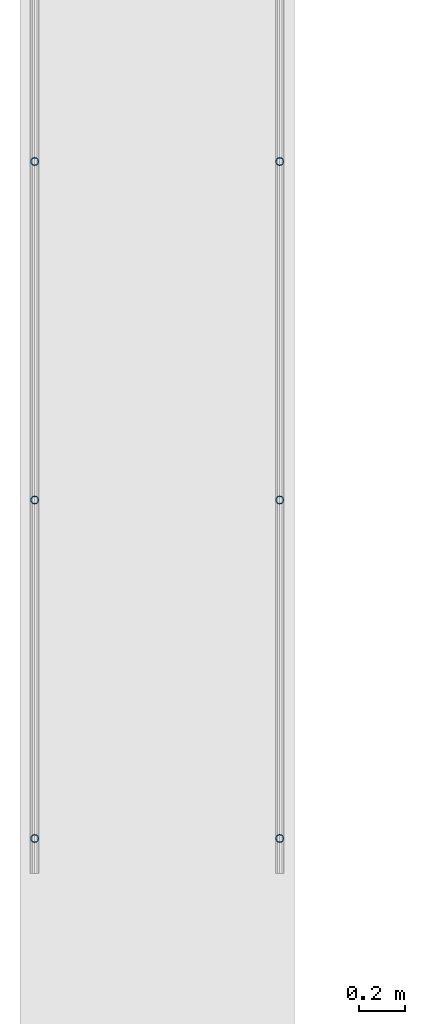
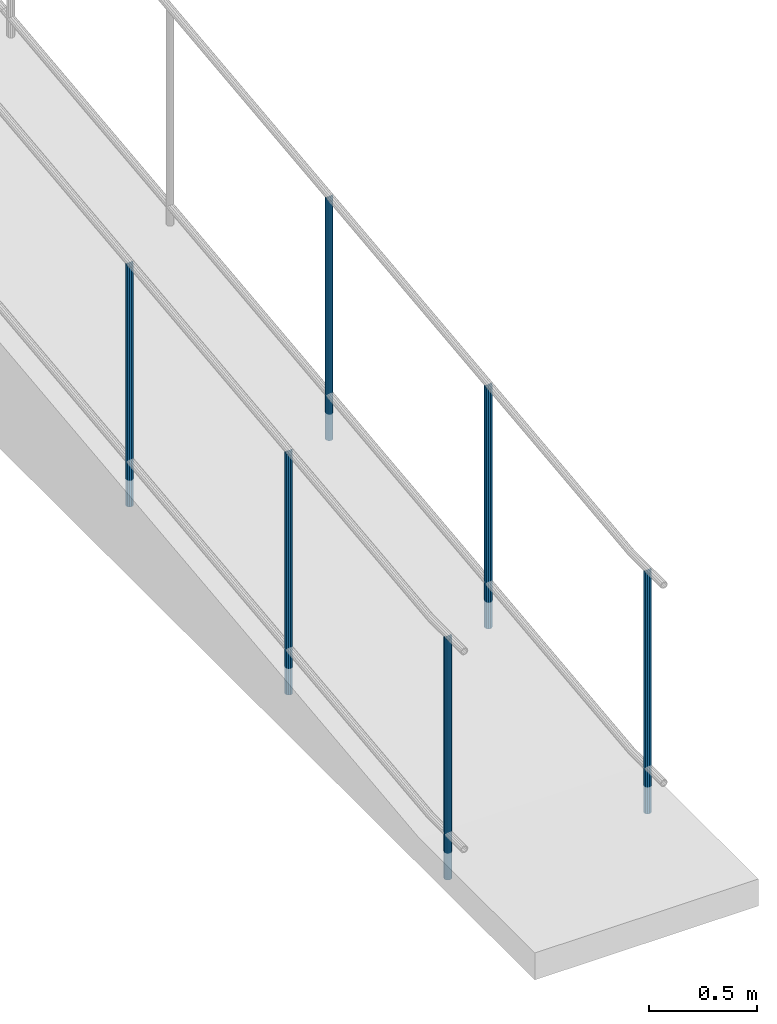
# One storey, part 871 of 1763: 6 columns, 2 elements without a shape of their own.
"""IFC2X3 building model written with IfcOpenShell, lengths in millimetres."""

from ifc_helpers import new_model, si_unit, frame, origin_with_axes, place, context, subcontext, project, spatial, faceted_brep, material, type_object, element, aggregate, save


model = new_model("IFC2X3")

# Units and contexts
model_context = context("Model", 3, precision=1e-05, world=origin_with_axes())
body_context = subcontext(model_context, "Body", "Model", "MODEL_VIEW")
ifc_project = project(units=[si_unit("LENGTHUNIT", "METRE", prefix="MILLI"), si_unit("AREAUNIT", "SQUARE_METRE"), si_unit("VOLUMEUNIT", "CUBIC_METRE"), si_unit("MASSUNIT", "GRAM", prefix="KILO"), si_unit("TIMEUNIT", "SECOND"), si_unit("PLANEANGLEUNIT", "RADIAN"), si_unit("SOLIDANGLEUNIT", "STERADIAN"), si_unit("THERMODYNAMICTEMPERATUREUNIT", "DEGREE_CELSIUS"), si_unit("LUMINOUSINTENSITYUNIT", "LUMEN")], contexts=[model_context])

# Site, building, storey
site_placement = place(None, origin_with_axes())
site = spatial("IfcSite", under=ifc_project, at=site_placement, CompositionType="ELEMENT")
building_placement = place(site_placement, origin_with_axes())
building = spatial("IfcBuilding", under=site, at=building_placement, Name="Undefined", CompositionType="ELEMENT")
storey_placement = place(building_placement, origin_with_axes())
storey = spatial("IfcBuildingStorey", under=building, at=storey_placement, Name="Undefined", CompositionType="ELEMENT", Elevation=0.0)

# Assembly, columns
assembly_1_placement = place(storey_placement, origin_with_axes())
assembly_1 = element("IfcElementAssembly", 1, at=assembly_1_placement, inside=storey, Name="GUARDRAIL", AssemblyPlace="NOTDEFINED", PredefinedType="RIGID_FRAME")
ifc_material = material(Name="STEEL/A513")
column_type = type_object("IfcColumnType", PredefinedType="NOTDEFINED")
column_1_placement = place(assembly_1_placement, frame((-97200.6527017878, -14255.9625831118, 3409.94906001946), z_axis=(0.0, -0.999999999989044, 4.68099999989136e-06), x_axis=(0.0, 4.68100000009712e-06, 0.999999999989044)))
column_1 = element("IfcColumn", 2, at=column_1_placement, type_object=column_type, material=ifc_material, Name="POST TUBE", context=body_context, shape_type="Brep", body=[
    faceted_brep([(1355.10215161049, -9.52499999999418, 16.4977839420062), (1355.10216136252, -9.52499999999418, 9.99208795648156), (1354.46410377855, -7.14375000000291, 12.3733379564819), (1352.54993886579, 0.0, 14.2874999999131), (1352.5499317268, 0.0, 19.0499999999138), (1354.46410377855, 7.14375000000291, 12.3733379564819), (1355.10216136252, 9.52499999999418, 9.99208795648156), (1355.10215161049, 9.52499999999418, 16.4977839420062), (1371.59999999763, 19.0500000000029, -8.9130480773747e-11), (1362.07494600479, 16.4977839420899, 9.52499999991051), (1362.07497456074, 16.4977839420899, -9.52500000008877), (1357.95050358876, 12.3733379565674, 7.14374999991196), (1359.86467634067, 14.2875000000058, -8.9130480773747e-11), (1357.95052500572, 12.3733379565674, -7.1437500000884), (1355.1021913188, 9.52499999999418, -9.992087956658), (1355.10220107084, 9.52499999999418, -16.4977839421827), (1354.46414087382, 7.14375000000291, -12.3733379566584), (1352.54998169972, 0.0, -14.2875000000895), (1352.5499888387, 0.0, -19.0500000000884), (1355.1021913188, -9.52499999999418, -9.992087956658), (1355.10220107084, -9.52499999999418, -16.4977839421827), (1354.46414087382, -7.14375000000291, -12.3733379566584), (1371.59996028277, -19.0500000000029, -1.4915713109076e-10), (1362.07497456074, -16.4977839420899, -9.52500000008877), (1362.07494600479, -16.4977839420899, 9.52499999991051), (1357.95052500571, -12.3733379565674, -7.1437500000884), (1359.86467634067, -14.2875000000058, -8.9130480773747e-11), (1357.95050358875, -12.3733379565674, 7.14374999991196), (0.0, -16.4977839420899, -9.52500000000146), (0.0, -9.52499999999418, -16.4977839420935), (1.45519152283669e-11, 1.81898940354586e-12, -19.0499999999993), (0.0, 9.52499999999418, -16.4977839420935), (0.0, 16.4977839420899, -9.52500000000146), (0.0, 19.0500000000029, 0.0), (0.0, 16.4977839420899, 9.52500000000146), (0.0, 9.52499999999418, 16.4977839420935), (1.45519152283669e-11, 1.81898940354586e-12, 19.0499999999993), (0.0, -9.52499999999418, 16.4977839420935), (0.0, -16.4977839420899, 9.52500000000146), (0.0, -19.0500000000029, 0.0), (0.0, -12.3733379565674, -7.14374999999927), (0.0, -7.14375000000291, -12.373337956571), (0.0, 0.0, -14.2874999999985), (0.0, 7.14375000000291, -12.373337956571), (0.0, 12.3733379565674, -7.14374999999927), (0.0, 14.2875000000058, 0.0), (0.0, 12.3733379565674, 7.14374999999927), (0.0, 7.14375000000291, 12.373337956571), (0.0, 0.0, 14.2874999999985), (0.0, -7.14375000000291, 12.373337956571), (0.0, -12.3733379565674, 7.14374999999927), (0.0, -14.2875000000058, 0.0)], [[[0, 1, 2, 3, 4]], [[4, 3, 5, 6, 7]], [[8, 9, 10]], [[7, 6, 11, 12, 13, 14, 15, 10, 9]], [[16, 17, 18, 15, 14]], [[19, 20, 18, 17, 21]], [[22, 23, 24]], [[24, 23, 20, 19, 25, 26, 27, 1, 0]], [[28, 29, 20, 23]], [[29, 30, 18, 20]], [[30, 31, 15, 18]], [[31, 32, 10, 15]], [[32, 33, 8, 10]], [[33, 34, 9, 8]], [[34, 35, 7, 9]], [[35, 36, 4, 7]], [[36, 37, 0, 4]], [[37, 38, 24, 0]], [[38, 39, 22, 24]], [[39, 28, 23, 22]], [[38, 37, 36, 35, 34, 33, 32, 31, 30, 29, 28, 39], [40, 41, 42, 43, 44, 45, 46, 47, 48, 49, 50, 51]], [[40, 51, 26, 25]], [[21, 41, 40, 25, 19]], [[42, 41, 21, 17]], [[43, 42, 17, 16]], [[44, 43, 16, 14, 13]], [[45, 44, 13, 12]], [[46, 45, 12, 11]], [[5, 47, 46, 11, 6]], [[48, 47, 5, 3]], [[49, 48, 3, 2]], [[50, 49, 2, 1, 27]], [[51, 50, 27, 26]]]),
])
column_2_placement = place(assembly_1_placement, frame((-97200.6527017878, -11309.562666814, 3730.72595269953), z_axis=(0.0, -0.999999999989044, 4.68099999989136e-06), x_axis=(0.0, 4.68100000009712e-06, 0.999999999989044)))
column_2 = element("IfcColumn", 3, at=column_2_placement, type_object=column_type, material=ifc_material, Name="POST TUBE", context=body_context, shape_type="Brep", body=[
    faceted_brep([(1371.60074802696, 19.0500000000029, -4.95674612466246e-10), (1360.91954353543, 16.4977839420899, 9.52499999992688), (1363.1068023618, 16.4977839420899, -9.52500000007285), (1352.93166657158, -7.14375000000291, 12.3733379564974), (1350.78515091293, 0.0, 14.2874999999276), (1350.23833620634, 0.0, 19.0499999999279), (1353.10035708436, -9.52499999999418, 16.4977839420208), (1353.84731986472, -9.52499999997963, 9.99208795651202), (1353.84731986473, 9.52500000000873, 9.99208795648292), (1353.10035708436, 9.52499999999418, 16.4977839420208), (1352.93166657157, 7.14375000000291, 12.3733379564974), (1357.04140787087, 12.3733379565674, 7.14374999992697), (1359.7883677507, 14.2875000000058, -7.27595761418343e-11), (1358.68185199063, 12.3733379565674, -7.14375000007294), (1356.14183772056, 9.52500000000873, -9.99208795662844), (1356.88880050093, 9.52499999999418, -16.4977839421663), (1355.77299913398, 7.14375000000291, -12.3733379566434), (1354.06603915248, 0.0, -14.2875000000727), (1354.61285385908, 0.0, -19.0500000000725), (1355.77299913399, -7.14375000000291, -12.3733379566434), (1356.14183772056, -9.52499999997963, -9.992087956658), (1356.88880050093, -9.52499999999418, -16.4977839421663), (1371.60075086449, -19.0499999999884, 1.21417542686686e-10), (1363.1068023618, -16.4977839420899, -9.52500000007285), (1360.91954353543, -16.4977839420899, 9.52499999992688), (1358.68185199066, -12.3733379565674, -7.14375000007294), (1359.78836775073, -14.2875000000058, -7.27595761418343e-11), (1357.0414078709, -12.3733379565674, 7.14374999992697), (0.0, -16.4977839420899, -9.52500000000146), (0.0, -9.52499999999418, -16.4977839420935), (1.45519152283669e-11, 1.81898940354586e-12, -19.0499999999993), (0.0, 9.52499999999418, -16.4977839420935), (0.0, 16.4977839420899, -9.52500000000146), (0.0, 19.0500000000029, 0.0), (0.0, 16.4977839420899, 9.52500000000146), (0.0, 9.52499999999418, 16.4977839420935), (1.45519152283669e-11, 1.81898940354586e-12, 19.0499999999993), (0.0, -9.52499999999418, 16.4977839420935), (0.0, -16.4977839420899, 9.52500000000146), (0.0, -19.0500000000029, 0.0), (0.0, -12.3733379565674, -7.14374999999927), (0.0, -7.14375000000291, -12.373337956571), (0.0, 0.0, -14.2874999999985), (0.0, 7.14375000000291, -12.373337956571), (0.0, 12.3733379565674, -7.14374999999927), (0.0, 14.2875000000058, 0.0), (0.0, 12.3733379565674, 7.14374999999927), (0.0, 7.14375000000291, 12.373337956571), (0.0, 0.0, 14.2874999999985), (0.0, -7.14375000000291, 12.373337956571), (0.0, -12.3733379565674, 7.14374999999927), (0.0, -14.2875000000058, 0.0)], [[[0, 1, 2]], [[3, 4, 5, 6, 7]], [[8, 9, 5, 4, 10]], [[2, 1, 9, 8, 11, 12, 13, 14, 15]], [[15, 14, 16, 17, 18]], [[18, 17, 19, 20, 21]], [[22, 23, 24]], [[21, 20, 25, 26, 27, 7, 6, 24, 23]], [[28, 29, 21, 23]], [[29, 30, 18, 21]], [[30, 31, 15, 18]], [[31, 32, 2, 15]], [[32, 33, 0, 2]], [[33, 34, 1, 0]], [[34, 35, 9, 1]], [[35, 36, 5, 9]], [[36, 37, 6, 5]], [[37, 38, 24, 6]], [[38, 39, 22, 24]], [[39, 28, 23, 22]], [[38, 37, 36, 35, 34, 33, 32, 31, 30, 29, 28, 39], [40, 41, 42, 43, 44, 45, 46, 47, 48, 49, 50, 51]], [[40, 51, 26, 25]], [[19, 41, 40, 25, 20]], [[42, 41, 19, 17]], [[43, 42, 17, 16]], [[44, 43, 16, 14, 13]], [[45, 44, 13, 12]], [[46, 45, 12, 11]], [[10, 47, 46, 11, 8]], [[48, 47, 10, 4]], [[49, 48, 4, 3]], [[50, 49, 3, 7, 27]], [[51, 50, 27, 26]]]),
])
column_3_placement = place(assembly_1_placement, frame((-97200.6527017878, -12782.7626686429, 3561.58505339819), z_axis=(0.0, -0.999999999989044, 4.68099999989136e-06), x_axis=(0.0, 4.68100000009712e-06, 0.999999999989044)))
column_3 = element("IfcColumn", 4, at=column_3_placement, type_object=column_type, material=ifc_material, Name="POST TUBE", context=body_context, shape_type="Brep", body=[
    faceted_brep([(1371.60074802696, 19.0500000000029, -4.95674612466246e-10), (1360.91954353543, 16.4977839420899, 9.52499999992688), (1363.1068023618, 16.4977839420899, -9.52500000007285), (1352.93166657158, -7.14375000000291, 12.3733379564974), (1350.78515091293, 0.0, 14.2874999999276), (1350.23833620634, 0.0, 19.0499999999279), (1353.10035708436, -9.52499999999418, 16.4977839420208), (1353.84731986472, -9.52499999997963, 9.99208795651202), (1353.84731986473, 9.52500000000873, 9.99208795648292), (1353.10035708436, 9.52499999999418, 16.4977839420208), (1352.93166657157, 7.14375000000291, 12.3733379564974), (1357.04140787087, 12.3733379565674, 7.14374999992697), (1359.7883677507, 14.2875000000058, -7.27595761418343e-11), (1358.68185199063, 12.3733379565674, -7.14375000007294), (1356.14183772056, 9.52500000000873, -9.99208795662844), (1356.88880050093, 9.52499999999418, -16.4977839421663), (1355.77299913398, 7.14375000000291, -12.3733379566434), (1354.06603915248, 0.0, -14.2875000000727), (1354.61285385908, 0.0, -19.0500000000725), (1355.77299913399, -7.14375000000291, -12.3733379566434), (1356.14183772056, -9.52499999997963, -9.992087956658), (1356.88880050093, -9.52499999999418, -16.4977839421663), (1371.60075086449, -19.0499999999884, 1.21417542686686e-10), (1363.1068023618, -16.4977839420899, -9.52500000007285), (1360.91954353543, -16.4977839420899, 9.52499999992688), (1358.68185199066, -12.3733379565674, -7.14375000007294), (1359.78836775073, -14.2875000000058, -7.27595761418343e-11), (1357.0414078709, -12.3733379565674, 7.14374999992697), (0.0, -16.4977839420899, -9.52500000000146), (0.0, -9.52499999999418, -16.4977839420935), (1.45519152283669e-11, 1.81898940354586e-12, -19.0499999999993), (0.0, 9.52499999999418, -16.4977839420935), (0.0, 16.4977839420899, -9.52500000000146), (0.0, 19.0500000000029, 0.0), (0.0, 16.4977839420899, 9.52500000000146), (0.0, 9.52499999999418, 16.4977839420935), (1.45519152283669e-11, 1.81898940354586e-12, 19.0499999999993), (0.0, -9.52499999999418, 16.4977839420935), (0.0, -16.4977839420899, 9.52500000000146), (0.0, -19.0500000000029, 0.0), (0.0, -12.3733379565674, -7.14374999999927), (0.0, -7.14375000000291, -12.373337956571), (0.0, 0.0, -14.2874999999985), (0.0, 7.14375000000291, -12.373337956571), (0.0, 12.3733379565674, -7.14374999999927), (0.0, 14.2875000000058, 0.0), (0.0, 12.3733379565674, 7.14374999999927), (0.0, 7.14375000000291, 12.373337956571), (0.0, 0.0, 14.2874999999985), (0.0, -7.14375000000291, 12.373337956571), (0.0, -12.3733379565674, 7.14374999999927), (0.0, -14.2875000000058, 0.0)], [[[0, 1, 2]], [[3, 4, 5, 6, 7]], [[8, 9, 5, 4, 10]], [[2, 1, 9, 8, 11, 12, 13, 14, 15]], [[15, 14, 16, 17, 18]], [[18, 17, 19, 20, 21]], [[22, 23, 24]], [[21, 20, 25, 26, 27, 7, 6, 24, 23]], [[28, 29, 21, 23]], [[29, 30, 18, 21]], [[30, 31, 15, 18]], [[31, 32, 2, 15]], [[32, 33, 0, 2]], [[33, 34, 1, 0]], [[34, 35, 9, 1]], [[35, 36, 5, 9]], [[36, 37, 6, 5]], [[37, 38, 24, 6]], [[38, 39, 22, 24]], [[39, 28, 23, 22]], [[38, 37, 36, 35, 34, 33, 32, 31, 30, 29, 28, 39], [40, 41, 42, 43, 44, 45, 46, 47, 48, 49, 50, 51]], [[40, 51, 26, 25]], [[19, 41, 40, 25, 20]], [[42, 41, 19, 17]], [[43, 42, 17, 16]], [[44, 43, 16, 14, 13]], [[45, 44, 13, 12]], [[46, 45, 12, 11]], [[10, 47, 46, 11, 8]], [[48, 47, 10, 4]], [[49, 48, 4, 3]], [[50, 49, 3, 7, 27]], [[51, 50, 27, 26]]]),
])
aggregate(assembly_1, [column_1, column_2, column_3])

assembly_2_placement = place(storey_placement, origin_with_axes())
assembly_2 = element("IfcElementAssembly", 5, at=assembly_2_placement, inside=storey, Name="GUARDRAIL", AssemblyPlace="NOTDEFINED", PredefinedType="RIGID_FRAME")
column_4_placement = place(assembly_2_placement, frame((-96133.8527017878, -14255.9625831118, 3409.94906001946), z_axis=(0.0, -0.999999999989044, 4.68099999989136e-06), x_axis=(0.0, 4.68100000009712e-06, 0.999999999989044)))
column_4 = element("IfcColumn", 6, at=column_4_placement, type_object=column_type, material=ifc_material, Name="POST TUBE", context=body_context, shape_type="Brep", body=[
    faceted_brep([(1355.10215161049, -9.52499999999418, 16.4977839420062), (1355.10216136252, -9.52499999999418, 9.99208795648156), (1354.46410377855, -7.14375000000291, 12.3733379564819), (1352.54993886579, 0.0, 14.2874999999131), (1352.5499317268, 0.0, 19.0499999999138), (1354.46410377855, 7.14375000000291, 12.3733379564819), (1355.10216136252, 9.52499999999418, 9.99208795648156), (1355.10215161049, 9.52499999999418, 16.4977839420062), (1371.59999999763, 19.0500000000029, -8.9130480773747e-11), (1362.07494600479, 16.4977839420899, 9.52499999991051), (1362.07497456074, 16.4977839420899, -9.52500000008877), (1357.95050358876, 12.3733379565674, 7.14374999991196), (1359.86467634067, 14.2875000000058, -8.9130480773747e-11), (1357.95052500572, 12.3733379565674, -7.1437500000884), (1355.1021913188, 9.52499999999418, -9.992087956658), (1355.10220107084, 9.52499999999418, -16.4977839421827), (1354.46414087382, 7.14375000000291, -12.3733379566584), (1352.54998169972, 0.0, -14.2875000000895), (1352.5499888387, 0.0, -19.0500000000884), (1355.1021913188, -9.52499999999418, -9.992087956658), (1355.10220107084, -9.52499999999418, -16.4977839421827), (1354.46414087382, -7.14375000000291, -12.3733379566584), (1371.59996028277, -19.0500000000029, -1.4915713109076e-10), (1362.07497456074, -16.4977839420899, -9.52500000008877), (1362.07494600479, -16.4977839420899, 9.52499999991051), (1357.95052500571, -12.3733379565674, -7.1437500000884), (1359.86467634067, -14.2875000000058, -8.9130480773747e-11), (1357.95050358875, -12.3733379565674, 7.14374999991196), (0.0, -16.4977839420899, -9.52500000000146), (0.0, -9.52499999999418, -16.4977839420935), (1.45519152283669e-11, 1.81898940354586e-12, -19.0499999999993), (0.0, 9.52499999999418, -16.4977839420935), (0.0, 16.4977839420899, -9.52500000000146), (0.0, 19.0500000000029, 0.0), (0.0, 16.4977839420899, 9.52500000000146), (0.0, 9.52499999999418, 16.4977839420935), (1.45519152283669e-11, 1.81898940354586e-12, 19.0499999999993), (0.0, -9.52499999999418, 16.4977839420935), (0.0, -16.4977839420899, 9.52500000000146), (0.0, -19.0500000000029, 0.0), (0.0, -12.3733379565674, -7.14374999999927), (0.0, -7.14375000000291, -12.373337956571), (0.0, 0.0, -14.2874999999985), (0.0, 7.14375000000291, -12.373337956571), (0.0, 12.3733379565674, -7.14374999999927), (0.0, 14.2875000000058, 0.0), (0.0, 12.3733379565674, 7.14374999999927), (0.0, 7.14375000000291, 12.373337956571), (0.0, 0.0, 14.2874999999985), (0.0, -7.14375000000291, 12.373337956571), (0.0, -12.3733379565674, 7.14374999999927), (0.0, -14.2875000000058, 0.0)], [[[0, 1, 2, 3, 4]], [[4, 3, 5, 6, 7]], [[8, 9, 10]], [[7, 6, 11, 12, 13, 14, 15, 10, 9]], [[16, 17, 18, 15, 14]], [[19, 20, 18, 17, 21]], [[22, 23, 24]], [[24, 23, 20, 19, 25, 26, 27, 1, 0]], [[28, 29, 20, 23]], [[29, 30, 18, 20]], [[30, 31, 15, 18]], [[31, 32, 10, 15]], [[32, 33, 8, 10]], [[33, 34, 9, 8]], [[34, 35, 7, 9]], [[35, 36, 4, 7]], [[36, 37, 0, 4]], [[37, 38, 24, 0]], [[38, 39, 22, 24]], [[39, 28, 23, 22]], [[38, 37, 36, 35, 34, 33, 32, 31, 30, 29, 28, 39], [40, 41, 42, 43, 44, 45, 46, 47, 48, 49, 50, 51]], [[40, 51, 26, 25]], [[21, 41, 40, 25, 19]], [[42, 41, 21, 17]], [[43, 42, 17, 16]], [[44, 43, 16, 14, 13]], [[45, 44, 13, 12]], [[46, 45, 12, 11]], [[5, 47, 46, 11, 6]], [[48, 47, 5, 3]], [[49, 48, 3, 2]], [[50, 49, 2, 1, 27]], [[51, 50, 27, 26]]]),
])
column_5_placement = place(assembly_2_placement, frame((-96133.8527017878, -11309.562666814, 3730.72595269953), z_axis=(0.0, -0.999999999989044, 4.68099999989136e-06), x_axis=(0.0, 4.68100000009712e-06, 0.999999999989044)))
column_5 = element("IfcColumn", 7, at=column_5_placement, type_object=column_type, material=ifc_material, Name="POST TUBE", context=body_context, shape_type="Brep", body=[
    faceted_brep([(1371.60074802696, 19.0500000000029, -4.95674612466246e-10), (1360.91954353543, 16.4977839420899, 9.52499999992688), (1363.1068023618, 16.4977839420899, -9.52500000007285), (1352.93166657158, -7.14375000000291, 12.3733379564974), (1350.78515091293, 0.0, 14.2874999999276), (1350.23833620634, 0.0, 19.0499999999279), (1353.10035708436, -9.52499999999418, 16.4977839420208), (1353.84731986472, -9.52499999997963, 9.99208795651202), (1353.84731986473, 9.52500000000873, 9.99208795648292), (1353.10035708436, 9.52499999999418, 16.4977839420208), (1352.93166657157, 7.14375000000291, 12.3733379564974), (1357.04140787087, 12.3733379565674, 7.14374999992697), (1359.7883677507, 14.2875000000058, -7.27595761418343e-11), (1358.68185199063, 12.3733379565674, -7.14375000007294), (1356.14183772056, 9.52500000000873, -9.99208795662844), (1356.88880050093, 9.52499999999418, -16.4977839421663), (1355.77299913398, 7.14375000000291, -12.3733379566434), (1354.06603915248, 0.0, -14.2875000000727), (1354.61285385908, 0.0, -19.0500000000725), (1355.77299913399, -7.14375000000291, -12.3733379566434), (1356.14183772056, -9.52499999997963, -9.992087956658), (1356.88880050093, -9.52499999999418, -16.4977839421663), (1371.60075086449, -19.0499999999884, 1.21417542686686e-10), (1363.1068023618, -16.4977839420899, -9.52500000007285), (1360.91954353543, -16.4977839420899, 9.52499999992688), (1358.68185199066, -12.3733379565674, -7.14375000007294), (1359.78836775073, -14.2875000000058, -7.27595761418343e-11), (1357.0414078709, -12.3733379565674, 7.14374999992697), (0.0, -16.4977839420899, -9.52500000000146), (0.0, -9.52499999999418, -16.4977839420935), (1.45519152283669e-11, 1.81898940354586e-12, -19.0499999999993), (0.0, 9.52499999999418, -16.4977839420935), (0.0, 16.4977839420899, -9.52500000000146), (0.0, 19.0500000000029, 0.0), (0.0, 16.4977839420899, 9.52500000000146), (0.0, 9.52499999999418, 16.4977839420935), (1.45519152283669e-11, 1.81898940354586e-12, 19.0499999999993), (0.0, -9.52499999999418, 16.4977839420935), (0.0, -16.4977839420899, 9.52500000000146), (0.0, -19.0500000000029, 0.0), (0.0, -12.3733379565674, -7.14374999999927), (0.0, -7.14375000000291, -12.373337956571), (0.0, 0.0, -14.2874999999985), (0.0, 7.14375000000291, -12.373337956571), (0.0, 12.3733379565674, -7.14374999999927), (0.0, 14.2875000000058, 0.0), (0.0, 12.3733379565674, 7.14374999999927), (0.0, 7.14375000000291, 12.373337956571), (0.0, 0.0, 14.2874999999985), (0.0, -7.14375000000291, 12.373337956571), (0.0, -12.3733379565674, 7.14374999999927), (0.0, -14.2875000000058, 0.0)], [[[0, 1, 2]], [[3, 4, 5, 6, 7]], [[8, 9, 5, 4, 10]], [[2, 1, 9, 8, 11, 12, 13, 14, 15]], [[15, 14, 16, 17, 18]], [[18, 17, 19, 20, 21]], [[22, 23, 24]], [[21, 20, 25, 26, 27, 7, 6, 24, 23]], [[28, 29, 21, 23]], [[29, 30, 18, 21]], [[30, 31, 15, 18]], [[31, 32, 2, 15]], [[32, 33, 0, 2]], [[33, 34, 1, 0]], [[34, 35, 9, 1]], [[35, 36, 5, 9]], [[36, 37, 6, 5]], [[37, 38, 24, 6]], [[38, 39, 22, 24]], [[39, 28, 23, 22]], [[38, 37, 36, 35, 34, 33, 32, 31, 30, 29, 28, 39], [40, 41, 42, 43, 44, 45, 46, 47, 48, 49, 50, 51]], [[40, 51, 26, 25]], [[19, 41, 40, 25, 20]], [[42, 41, 19, 17]], [[43, 42, 17, 16]], [[44, 43, 16, 14, 13]], [[45, 44, 13, 12]], [[46, 45, 12, 11]], [[10, 47, 46, 11, 8]], [[48, 47, 10, 4]], [[49, 48, 4, 3]], [[50, 49, 3, 7, 27]], [[51, 50, 27, 26]]]),
])
column_6_placement = place(assembly_2_placement, frame((-96133.8527017878, -12782.7626686429, 3561.58505339819), z_axis=(0.0, -0.999999999989044, 4.68099999989136e-06), x_axis=(0.0, 4.68100000009712e-06, 0.999999999989044)))
column_6 = element("IfcColumn", 8, at=column_6_placement, type_object=column_type, material=ifc_material, Name="POST TUBE", context=body_context, shape_type="Brep", body=[
    faceted_brep([(1371.60074802696, 19.0500000000029, -4.95674612466246e-10), (1360.91954353543, 16.4977839420899, 9.52499999992688), (1363.1068023618, 16.4977839420899, -9.52500000007285), (1352.93166657158, -7.14375000000291, 12.3733379564974), (1350.78515091293, 0.0, 14.2874999999276), (1350.23833620634, 0.0, 19.0499999999279), (1353.10035708436, -9.52499999999418, 16.4977839420208), (1353.84731986472, -9.52499999997963, 9.99208795651202), (1353.84731986473, 9.52500000000873, 9.99208795648292), (1353.10035708436, 9.52499999999418, 16.4977839420208), (1352.93166657157, 7.14375000000291, 12.3733379564974), (1357.04140787087, 12.3733379565674, 7.14374999992697), (1359.7883677507, 14.2875000000058, -7.27595761418343e-11), (1358.68185199063, 12.3733379565674, -7.14375000007294), (1356.14183772056, 9.52500000000873, -9.99208795662844), (1356.88880050093, 9.52499999999418, -16.4977839421663), (1355.77299913398, 7.14375000000291, -12.3733379566434), (1354.06603915248, 0.0, -14.2875000000727), (1354.61285385908, 0.0, -19.0500000000725), (1355.77299913399, -7.14375000000291, -12.3733379566434), (1356.14183772056, -9.52499999997963, -9.992087956658), (1356.88880050093, -9.52499999999418, -16.4977839421663), (1371.60075086449, -19.0499999999884, 1.21417542686686e-10), (1363.1068023618, -16.4977839420899, -9.52500000007285), (1360.91954353543, -16.4977839420899, 9.52499999992688), (1358.68185199066, -12.3733379565674, -7.14375000007294), (1359.78836775073, -14.2875000000058, -7.27595761418343e-11), (1357.0414078709, -12.3733379565674, 7.14374999992697), (0.0, -16.4977839420899, -9.52500000000146), (0.0, -9.52499999999418, -16.4977839420935), (1.45519152283669e-11, 1.81898940354586e-12, -19.0499999999993), (0.0, 9.52499999999418, -16.4977839420935), (0.0, 16.4977839420899, -9.52500000000146), (0.0, 19.0500000000029, 0.0), (0.0, 16.4977839420899, 9.52500000000146), (0.0, 9.52499999999418, 16.4977839420935), (1.45519152283669e-11, 1.81898940354586e-12, 19.0499999999993), (0.0, -9.52499999999418, 16.4977839420935), (0.0, -16.4977839420899, 9.52500000000146), (0.0, -19.0500000000029, 0.0), (0.0, -12.3733379565674, -7.14374999999927), (0.0, -7.14375000000291, -12.373337956571), (0.0, 0.0, -14.2874999999985), (0.0, 7.14375000000291, -12.373337956571), (0.0, 12.3733379565674, -7.14374999999927), (0.0, 14.2875000000058, 0.0), (0.0, 12.3733379565674, 7.14374999999927), (0.0, 7.14375000000291, 12.373337956571), (0.0, 0.0, 14.2874999999985), (0.0, -7.14375000000291, 12.373337956571), (0.0, -12.3733379565674, 7.14374999999927), (0.0, -14.2875000000058, 0.0)], [[[0, 1, 2]], [[3, 4, 5, 6, 7]], [[8, 9, 5, 4, 10]], [[2, 1, 9, 8, 11, 12, 13, 14, 15]], [[15, 14, 16, 17, 18]], [[18, 17, 19, 20, 21]], [[22, 23, 24]], [[21, 20, 25, 26, 27, 7, 6, 24, 23]], [[28, 29, 21, 23]], [[29, 30, 18, 21]], [[30, 31, 15, 18]], [[31, 32, 2, 15]], [[32, 33, 0, 2]], [[33, 34, 1, 0]], [[34, 35, 9, 1]], [[35, 36, 5, 9]], [[36, 37, 6, 5]], [[37, 38, 24, 6]], [[38, 39, 22, 24]], [[39, 28, 23, 22]], [[38, 37, 36, 35, 34, 33, 32, 31, 30, 29, 28, 39], [40, 41, 42, 43, 44, 45, 46, 47, 48, 49, 50, 51]], [[40, 51, 26, 25]], [[19, 41, 40, 25, 20]], [[42, 41, 19, 17]], [[43, 42, 17, 16]], [[44, 43, 16, 14, 13]], [[45, 44, 13, 12]], [[46, 45, 12, 11]], [[10, 47, 46, 11, 8]], [[48, 47, 10, 4]], [[49, 48, 4, 3]], [[50, 49, 3, 7, 27]], [[51, 50, 27, 26]]]),
])
aggregate(assembly_2, [column_4, column_5, column_6])

save(model, "model.ifc")
